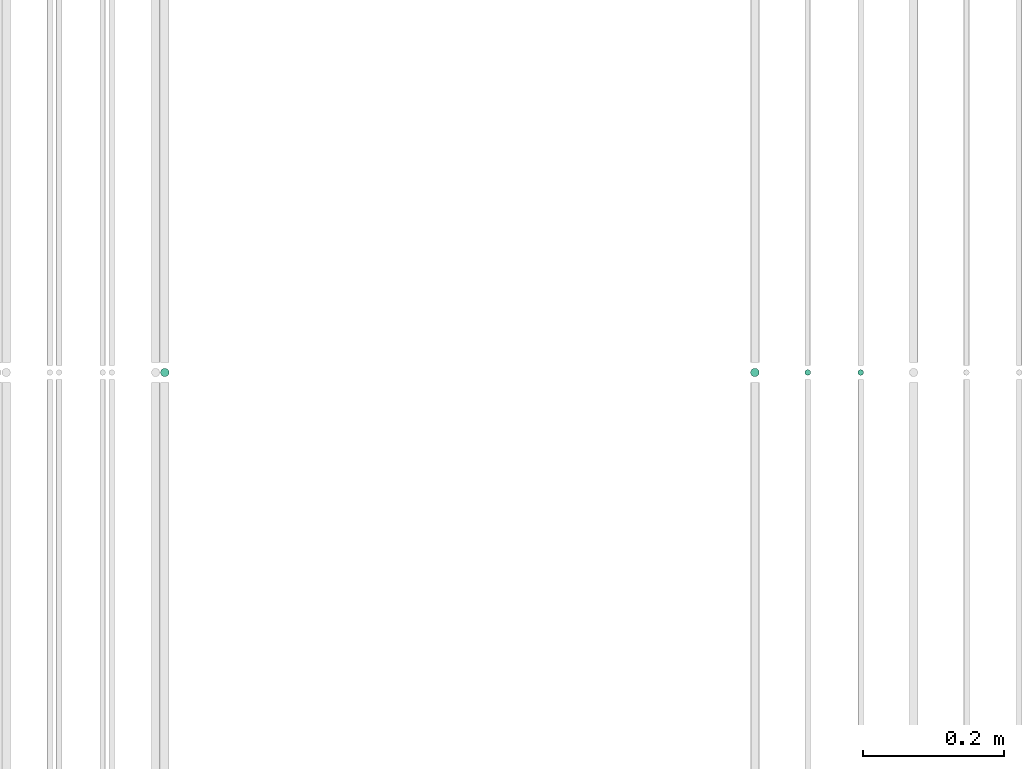
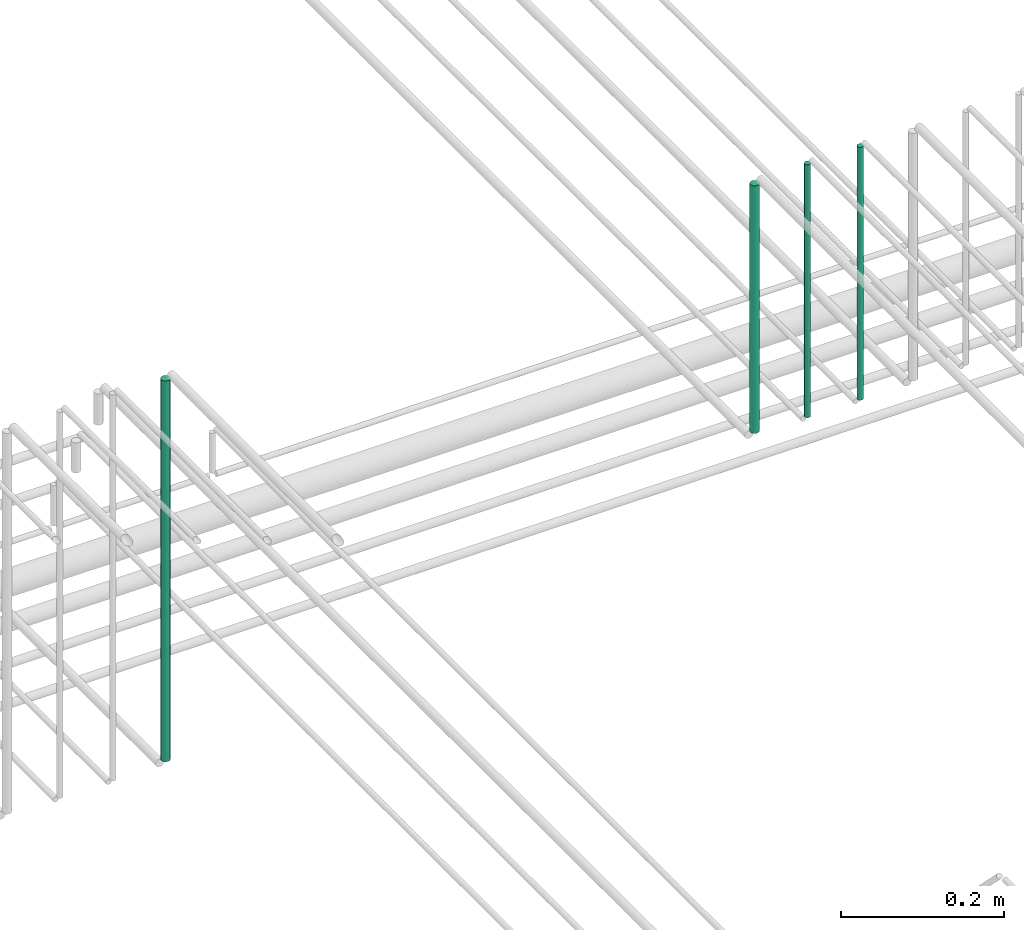
# One storey, part 146 of 331: 4 flow segments.
"""IFC2X3 building model written with IfcOpenShell, lengths in millimetres."""

from ifc_helpers import new_model, entity, si_unit, converted_unit, derived_unit, direction, frame, origin, origin_2d_with_axis, place, context, subcontext, project, spatial, circle, extrude, type_object, element, save


model = new_model("IFC2X3")

# Units and contexts
model_context = context("Model", 3, precision=0.01, world=origin(), true_north=direction((6.12303176911189e-17, 1.0)))
body_context = subcontext(model_context, "Body", "Model", "MODEL_VIEW")
ifc_project = project(units=[si_unit("LENGTHUNIT", "METRE", prefix="MILLI"), si_unit("AREAUNIT", "SQUARE_METRE"), si_unit("VOLUMEUNIT", "CUBIC_METRE"), converted_unit("PLANEANGLEUNIT", "DEGREE", entity("IfcRatioMeasure", 0.0174532925199433), si_unit("PLANEANGLEUNIT", "RADIAN"), dimensions=[0, 0, 0, 0, 0, 0, 0]), si_unit("MASSUNIT", "GRAM", prefix="KILO"), derived_unit("MASSDENSITYUNIT", [(si_unit("MASSUNIT", "GRAM", prefix="KILO"), 1), (si_unit("LENGTHUNIT", "METRE"), -3)]), derived_unit("MOMENTOFINERTIAUNIT", [(si_unit("LENGTHUNIT", "METRE"), 4)]), si_unit("TIMEUNIT", "SECOND"), si_unit("FREQUENCYUNIT", "HERTZ"), si_unit("THERMODYNAMICTEMPERATUREUNIT", "DEGREE_CELSIUS"), derived_unit("THERMALTRANSMITTANCEUNIT", [(si_unit("MASSUNIT", "GRAM", prefix="KILO"), 1), (si_unit("THERMODYNAMICTEMPERATUREUNIT", "KELVIN"), -1), (si_unit("TIMEUNIT", "SECOND"), -3)]), derived_unit("VOLUMETRICFLOWRATEUNIT", [(si_unit("LENGTHUNIT", "METRE"), 3), (si_unit("TIMEUNIT", "SECOND"), -1)]), derived_unit("MASSFLOWRATEUNIT", [(si_unit("MASSUNIT", "GRAM", prefix="KILO"), 1), (si_unit("TIMEUNIT", "SECOND"), -1)]), derived_unit("ROTATIONALFREQUENCYUNIT", [(si_unit("TIMEUNIT", "SECOND"), -1)]), si_unit("ELECTRICCURRENTUNIT", "AMPERE"), si_unit("ELECTRICVOLTAGEUNIT", "VOLT"), si_unit("POWERUNIT", "WATT"), si_unit("FORCEUNIT", "NEWTON", prefix="KILO"), si_unit("ILLUMINANCEUNIT", "LUX"), si_unit("LUMINOUSFLUXUNIT", "LUMEN"), si_unit("LUMINOUSINTENSITYUNIT", "CANDELA"), derived_unit("USERDEFINED", [(si_unit("MASSUNIT", "GRAM", prefix="KILO"), -1), (si_unit("LENGTHUNIT", "METRE"), -2), (si_unit("TIMEUNIT", "SECOND"), 3), (si_unit("LUMINOUSFLUXUNIT", "LUMEN"), 1)]), derived_unit("LINEARVELOCITYUNIT", [(si_unit("LENGTHUNIT", "METRE"), 1), (si_unit("TIMEUNIT", "SECOND"), -1)]), si_unit("PRESSUREUNIT", "PASCAL"), derived_unit("USERDEFINED", [(si_unit("LENGTHUNIT", "METRE"), -2), (si_unit("MASSUNIT", "GRAM", prefix="KILO"), 1), (si_unit("TIMEUNIT", "SECOND"), -2)]), derived_unit("LINEARFORCEUNIT", [(si_unit("MASSUNIT", "GRAM", prefix="KILO"), 1), (si_unit("LENGTHUNIT", "METRE"), 1), (si_unit("TIMEUNIT", "SECOND"), -2), (si_unit("LENGTHUNIT", "METRE"), -1)]), derived_unit("PLANARFORCEUNIT", [(si_unit("MASSUNIT", "GRAM", prefix="KILO"), 1), (si_unit("LENGTHUNIT", "METRE"), 1), (si_unit("TIMEUNIT", "SECOND"), -2), (si_unit("LENGTHUNIT", "METRE"), -2)])], contexts=[model_context])

# Site, building, storey
site_placement = place(None, frame((0.0, -0.00077364408347762, 0.0)))
site = spatial("IfcSite", under=ifc_project, at=site_placement, CompositionType="ELEMENT")
building_placement = place(site_placement, origin())
building = spatial("IfcBuilding", under=site, at=building_placement, CompositionType="ELEMENT")
storey_placement = place(building_placement, origin())
storey = spatial("IfcBuildingStorey", under=building, at=storey_placement, CompositionType="ELEMENT", Elevation=0.0)

# Flow segments
pipe_segment_type = type_object("IfcPipeSegmentType", PredefinedType="NOTDEFINED")
for number, where in (
    (1, (35540.5130615671, 5638.02529159149, 14760.0)),
    (2, (35465.5130615671, 5638.02529159149, 14760.0)),
):
    element("IfcFlowSegment", number, at=place(storey_placement, frame(where)), inside=storey, type_object=pipe_segment_type, context=body_context, shape_type="SweptSolid", body=[
        extrude(circle(Radius=4.0, at=origin_2d_with_axis()), frame((5.59527223591499, 5.59527223591607, 0.0), z_axis=(0.0, 0.0, 1.0), x_axis=(-1.0, 0.0, 0.0)), (0.0, 0.0, 1.0), 379.999999999979),
    ])
flow_segment_1_placement = place(storey_placement, frame((35388.5130615671, 5636.02529159149, 14764.0)))
element("IfcFlowSegment", 3, at=flow_segment_1_placement, inside=storey, type_object=pipe_segment_type, context=body_context, shape_type="SweptSolid", body=[
    extrude(circle(Radius=6.0, at=origin_2d_with_axis()), frame((7.59527223591454, 7.59527223591562, 0.0), z_axis=(0.0, 0.0, 1.0), x_axis=(-1.0, 0.0, 0.0)), (0.0, 0.0, 1.0), 371.999999999989),
])
flow_segment_2_placement = place(storey_placement, frame((34551.5132627125, 5636.02529159149, 14564.0)))
element("IfcFlowSegment", 4, at=flow_segment_2_placement, inside=storey, type_object=pipe_segment_type, context=body_context, shape_type="SweptSolid", body=[
    extrude(circle(Radius=6.0, at=origin_2d_with_axis()), frame((7.59527223591454, 7.59527223591562, 0.0), z_axis=(0.0, 0.0, 1.0), x_axis=(-1.0, 0.0, 0.0)), (0.0, 0.0, 1.0), 572.000000000011),
])

save(model, "model.ifc")
